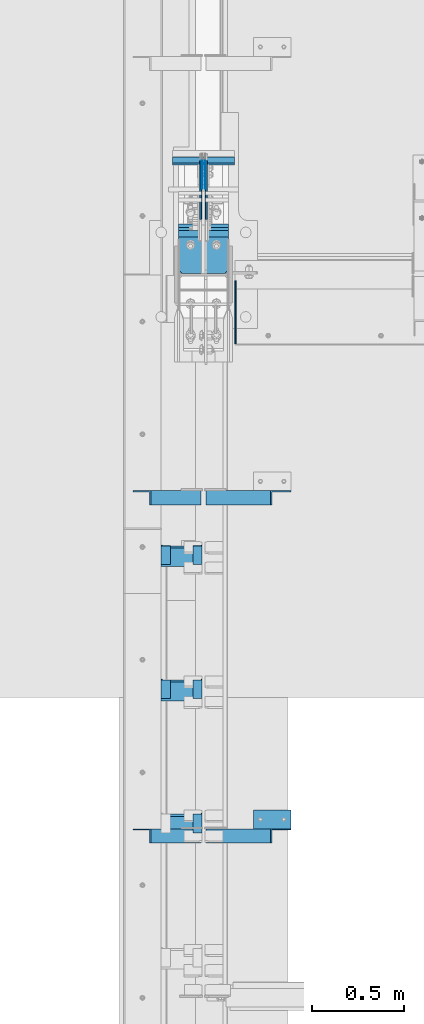
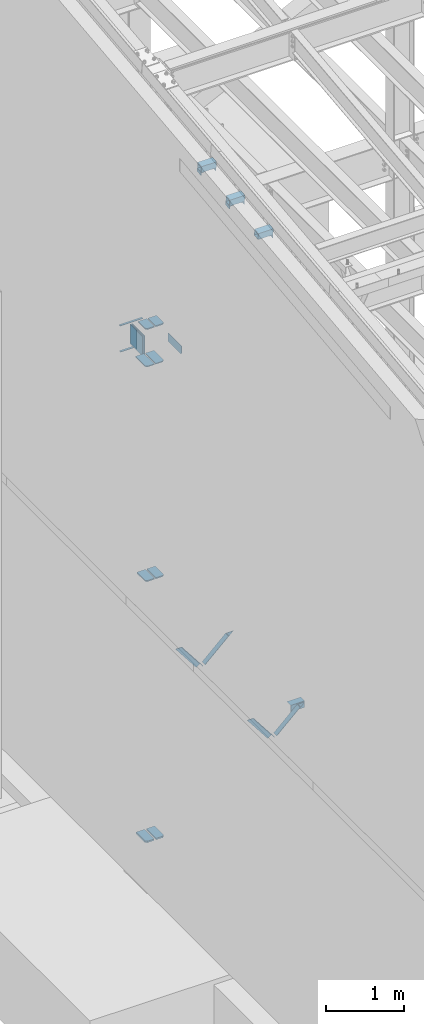
# One storey, part 829 of 1179: 24 beams, 4 members, 17 elements without a shape of their own.
"""IFC2X3 building model written with IfcOpenShell, lengths in millimetres."""

from ifc_helpers import new_model, si_unit, frame, origin_with_axes, place, context, subcontext, project, spatial, faceted_brep, material, type_object, element, aggregate, save


model = new_model("IFC2X3")

# Units and contexts
model_context = context("Model", 3, precision=1e-05, world=origin_with_axes())
body_context = subcontext(model_context, "Body", "Model", "MODEL_VIEW")
ifc_project = project(units=[si_unit("LENGTHUNIT", "METRE", prefix="MILLI"), si_unit("AREAUNIT", "SQUARE_METRE"), si_unit("VOLUMEUNIT", "CUBIC_METRE"), si_unit("MASSUNIT", "GRAM", prefix="KILO"), si_unit("TIMEUNIT", "SECOND"), si_unit("PLANEANGLEUNIT", "RADIAN"), si_unit("SOLIDANGLEUNIT", "STERADIAN"), si_unit("THERMODYNAMICTEMPERATUREUNIT", "DEGREE_CELSIUS"), si_unit("LUMINOUSINTENSITYUNIT", "LUMEN")], contexts=[model_context])

# Site, building, storey
site_placement = place(None, origin_with_axes())
site = spatial("IfcSite", under=ifc_project, at=site_placement, CompositionType="ELEMENT")
building_placement = place(site_placement, origin_with_axes())
building = spatial("IfcBuilding", under=site, at=building_placement, Name="Undefined", CompositionType="ELEMENT")
storey_placement = place(building_placement, origin_with_axes())
storey = spatial("IfcBuildingStorey", under=building, at=storey_placement, Name="Undefined", CompositionType="ELEMENT", Elevation=0.0)

# Assembly, member
assembly_1_placement = place(storey_placement, origin_with_axes())
assembly_1 = element("IfcElementAssembly", 1, at=assembly_1_placement, inside=storey, Name="ANGLE", AssemblyPlace="NOTDEFINED", PredefinedType="RIGID_FRAME")
ifc_material_1 = material(Name="STEEL/A36")
member_type = type_object("IfcMemberType", Name="L3X3X1/4", PredefinedType="NOTDEFINED")
member_1_placement = place(assembly_1_placement, frame((472.414639168561, 25844.5, 3736.19330123132), z_axis=(0.0, -1.0, 0.0), x_axis=(0.729484494811633, 0.0, 0.683997347823379)))
member_1 = element("IfcMember", 2, at=member_1_placement, type_object=member_type, material=ifc_material_1, Name="ANGLE", ObjectType="L3X3X1/4", context=body_context, shape_type="Brep", body=[
    faceted_brep([(0.0, 38.0999999999985, -38.0999999999999), (0.0, 38.0999999999985, 38.0999999999999), (475.752341075195, 38.0999999999181, 38.1000000000004), (475.752341075195, 38.0999999999181, -38.1000000000004), (0.0, 31.75, 38.1000000000004), (482.524628360803, 31.7499999999177, 38.1000000000004), (0.0, 31.75, -31.75), (482.524628360803, 31.7499999999177, -31.75), (0.0, -38.0999999999985, -31.75), (557.019788502486, -38.1000000000854, -31.75), (0.0, -38.0999999999985, -38.0999999999999), (557.019788502486, -38.1000000000854, -38.1000000000004)], [[[0, 1, 2, 3]], [[1, 4, 5, 2]], [[4, 6, 7, 5]], [[6, 8, 9, 7]], [[8, 10, 11, 9]], [[10, 0, 3, 11]], [[5, 7, 9, 11, 3, 2]], [[10, 8, 6, 4, 1, 0]]]),
])
aggregate(assembly_1, [member_1])

assembly_2_placement = place(storey_placement, origin_with_axes())
assembly_2 = element("IfcElementAssembly", 3, at=assembly_2_placement, inside=storey, Name="ANGLE", AssemblyPlace="NOTDEFINED", PredefinedType="RIGID_FRAME")
member_2_placement = place(assembly_2_placement, frame((472.414639168561, 24015.7, 3736.19330123132), z_axis=(0.0, -1.0, 0.0), x_axis=(0.729484494811633, 0.0, 0.683997347823379)))
member_2 = element("IfcMember", 4, at=member_2_placement, type_object=member_type, material=ifc_material_1, Name="ANGLE", ObjectType="L3X3X1/4", context=body_context, shape_type="Brep", body=[
    faceted_brep([(0.0, 38.0999999999985, -38.0999999999999), (0.0, 38.0999999999985, 38.0999999999999), (475.752341075195, 38.0999999999181, 38.1000000000004), (475.752341075195, 38.0999999999181, -38.1000000000004), (0.0, 31.75, 38.1000000000004), (482.524628360803, 31.7499999999177, 38.1000000000004), (0.0, 31.75, -31.75), (482.524628360803, 31.7499999999177, -31.75), (0.0, -38.0999999999985, -31.75), (557.019788502486, -38.1000000000854, -31.75), (0.0, -38.0999999999985, -38.0999999999999), (557.019788502486, -38.1000000000854, -38.1000000000004)], [[[0, 1, 2, 3]], [[1, 4, 5, 2]], [[4, 6, 7, 5]], [[6, 8, 9, 7]], [[8, 10, 11, 9]], [[10, 0, 3, 11]], [[5, 7, 9, 11, 3, 2]], [[10, 8, 6, 4, 1, 0]]]),
])
aggregate(assembly_2, [member_2])

assembly_3_placement = place(storey_placement, origin_with_axes())
assembly_3 = element("IfcElementAssembly", 5, at=assembly_3_placement, inside=storey, Name="ANGLE", AssemblyPlace="NOTDEFINED", PredefinedType="RIGID_FRAME")
member_3_placement = place(assembly_3_placement, frame((80.8196258456446, 25844.5, 4125.56128839178), z_axis=(0.0, -1.0, 0.0), x_axis=(0.614083067285056, 0.0, -0.789241399366364)))
member_3 = element("IfcMember", 6, at=member_3_placement, type_object=member_type, material=ifc_material_1, Name="ANGLE", ObjectType="L3X3X1/4", context=body_context, shape_type="Brep", body=[
    faceted_brep([(59.3707492954454, 38.0999999999781, -38.1000000000004), (59.3707492954454, 38.0999999999781, 38.1000000000004), (499.083854779058, 38.0999999998585, 38.1000000000004), (499.083854779058, 38.0999999998585, -38.1000000000004), (54.4300207928691, 31.7499999999804, 38.1000000000004), (499.083854779056, 31.7499999998595, 38.1000000000004), (54.4300207928691, 31.7499999999804, -31.75), (499.083854779056, 31.7499999998595, -31.75), (0.0820072645328764, -38.0999999999945, -31.75), (499.083854779043, -38.10000000013, -31.75), (0.0820072645328764, -38.0999999999945, -38.1000000000004), (499.083854779043, -38.10000000013, -38.1000000000004)], [[[0, 1, 2, 3]], [[1, 4, 5, 2]], [[4, 6, 7, 5]], [[6, 8, 9, 7]], [[8, 10, 11, 9]], [[10, 0, 3, 11]], [[5, 7, 9, 11, 3, 2]], [[10, 8, 6, 4, 1, 0]]]),
])
aggregate(assembly_3, [member_3])

assembly_4_placement = place(storey_placement, origin_with_axes())
assembly_4 = element("IfcElementAssembly", 7, at=assembly_4_placement, inside=storey, Name="ANGLE", AssemblyPlace="NOTDEFINED", PredefinedType="RIGID_FRAME")
member_4_placement = place(assembly_4_placement, frame((80.8196258456446, 24015.7, 4125.56128839178), z_axis=(0.0, -1.0, 0.0), x_axis=(0.614083067285056, 0.0, -0.789241399366364)))
member_4 = element("IfcMember", 8, at=member_4_placement, type_object=member_type, material=ifc_material_1, Name="ANGLE", ObjectType="L3X3X1/4", context=body_context, shape_type="Brep", body=[
    faceted_brep([(59.3707492954454, 38.0999999999781, -38.1000000000004), (59.3707492954454, 38.0999999999781, 38.1000000000004), (499.083854779058, 38.0999999998585, 38.1000000000004), (499.083854779058, 38.0999999998585, -38.1000000000004), (54.4300207928691, 31.7499999999804, 38.1000000000004), (499.083854779056, 31.7499999998595, 38.1000000000004), (54.4300207928691, 31.7499999999804, -31.75), (499.083854779056, 31.7499999998595, -31.75), (0.0820072645328764, -38.0999999999945, -31.75), (499.083854779043, -38.10000000013, -31.75), (0.0820072645328764, -38.0999999999945, -38.1000000000004), (499.083854779043, -38.10000000013, -38.1000000000004)], [[[0, 1, 2, 3]], [[1, 4, 5, 2]], [[4, 6, 7, 5]], [[6, 8, 9, 7]], [[8, 10, 11, 9]], [[10, 0, 3, 11]], [[5, 7, 9, 11, 3, 2]], [[10, 8, 6, 4, 1, 0]]]),
])
aggregate(assembly_4, [member_4])

# Assembly, beams
assembly_5_placement = place(storey_placement, origin_with_axes())
assembly_5 = element("IfcElementAssembly", 9, at=assembly_5_placement, inside=storey, Name="BEAM", AssemblyPlace="NOTDEFINED", PredefinedType="RIGID_FRAME")
ifc_material_2 = material(Name="STEEL/A572-GR.50")
beam_type_1 = type_object("IfcBeamType", PredefinedType="NOTDEFINED")
beam_1_placement = place(assembly_5_placement, frame((431.80003662088, 27643.7268058729, 7589.8375), z_axis=(-1.0, 0.0, 0.0), x_axis=(0.0, 1.0, 0.0)))
beam_1 = element("IfcBeam", 10, at=beam_1_placement, type_object=beam_type_1, material=ifc_material_2, Name="PLATE", context=body_context, shape_type="Brep", body=[
    faceted_brep([(0.0, 4.76249999999982, -168.275000000001), (0.0, 4.76250000000073, 168.275), (31.75, 4.76249999999982, 168.275000000001), (31.75, 4.76249999999982, -168.275000000001), (0.0, -4.76250000000073, 168.275), (31.75, -4.76249999999982, 168.275000000001), (0.0, -4.76249999999982, -168.275000000001), (31.75, -4.76249999999982, -168.275000000001)], [[[0, 1, 2, 3]], [[1, 4, 5, 2]], [[4, 6, 7, 5]], [[6, 0, 3, 7]], [[5, 7, 3, 2]], [[6, 4, 1, 0]]]),
])
beam_2_placement = place(assembly_5_placement, frame((431.80003662088, 27654.8389034115, 7989.4905), z_axis=(-1.0, 0.0, 0.0), x_axis=(0.0, 1.0, 0.0)))
beam_2 = element("IfcBeam", 11, at=beam_2_placement, type_object=beam_type_1, material=ifc_material_2, Name="PLATE", context=body_context, shape_type="Brep", body=[
    faceted_brep([(0.0, 4.76249999999982, -168.275000000001), (0.0, 4.76250000000073, 168.275), (31.75, 4.76249999999982, 168.275000000001), (31.75, 4.76249999999982, -168.275000000001), (0.0, -4.76250000000073, 168.275), (31.75, -4.76249999999982, 168.275000000001), (0.0, -4.76249999999982, -168.275000000001), (31.75, -4.76249999999982, -168.275000000001)], [[[0, 1, 2, 3]], [[1, 4, 5, 2]], [[4, 6, 7, 5]], [[6, 0, 3, 7]], [[5, 7, 3, 2]], [[6, 4, 1, 0]]]),
])

assembly_6_placement = place(storey_placement, origin_with_axes())
assembly_6 = element("IfcElementAssembly", 12, at=assembly_6_placement, inside=storey, Name="COLUMN", AssemblyPlace="NOTDEFINED", PredefinedType="RIGID_FRAME")
beam_type_2 = type_object("IfcBeamType", PredefinedType="NOTDEFINED")
beam_3_placement = place(assembly_6_placement, frame((505.619000000002, 27288.7322991348, 4353.49928057188), z_axis=(1.0, 0.0, 0.0), x_axis=(0.0, -1.0, 0.0)))
beam_3 = element("IfcBeam", 13, at=beam_3_placement, type_object=beam_type_2, material=ifc_material_2, Name="PLATE", context=body_context, shape_type="Brep", body=[
    faceted_brep([(231.382299134722, -9.52499999999964, 42.8617503813238), (231.382299134766, 9.52499999999964, 42.8617503813238), (211.537549516099, 9.52499999999964, 62.7065), (211.537549516099, -9.52499999999964, 62.7065), (6.18456397205591e-11, -9.52499999999964, -62.7065000000084), (0.0, -9.52499999999964, 62.7065000000002), (0.0, 9.52499999999964, 62.7065000000002), (6.18456397205591e-11, 9.52499999999964, -62.7065000000084), (231.382299199602, 9.52499999999964, -62.7065000000002), (231.382299199602, -9.52499999999964, -62.7065000000002)], [[[0, 1, 2, 3]], [[4, 5, 6, 7]], [[4, 7, 8, 9]], [[5, 4, 9, 0, 3]], [[6, 5, 3, 2]], [[8, 7, 6, 2, 1]], [[9, 8, 1, 0]]]),
])
beam_4_placement = place(assembly_6_placement, frame((357.981000000002, 27288.7322991348, 4353.49928057188), z_axis=(-1.0, 0.0, 0.0), x_axis=(0.0, -1.0, 0.0)))
beam_4 = element("IfcBeam", 14, at=beam_4_placement, type_object=beam_type_2, material=ifc_material_2, Name="PLATE", context=body_context, shape_type="Brep", body=[
    faceted_brep([(231.38229913473, -9.52499999999964, 42.8620431057086), (231.382299134766, 9.52499999999964, 42.8620431057086), (211.537842240497, 9.52499999999964, 62.7065), (211.537842240497, -9.52499999999964, 62.7065), (6.18456397205591e-11, -9.52499999999964, -62.7065000000084), (0.0, -9.52499999999964, 62.7065000000002), (0.0, 9.52499999999964, 62.7065000000002), (6.18456397205591e-11, 9.52499999999964, -62.7065000000084), (231.382299199602, 9.52499999999964, -62.7065000000002), (231.382299199602, -9.52499999999964, -62.7065000000002)], [[[0, 1, 2, 3]], [[4, 5, 6, 7]], [[4, 7, 8, 9]], [[5, 4, 9, 0, 3]], [[6, 5, 3, 2]], [[8, 7, 6, 2, 1]], [[9, 8, 1, 0]]]),
])

# Assembly, beam
assembly_7_placement = place(storey_placement, origin_with_axes())
assembly_7 = element("IfcElementAssembly", 15, at=assembly_7_placement, inside=storey, Name="BEAM", AssemblyPlace="NOTDEFINED", PredefinedType="RIGID_FRAME")
beam_type_3 = type_object("IfcBeamType", Name="L2X2X1/4", PredefinedType="NOTDEFINED")
beam_5_placement = place(assembly_7_placement, frame((228.599999999967, 25587.0004508329, 11703.4894001851), z_axis=(0.0, 0.112284087038014, -0.993676146336441), x_axis=(0.0, -0.993676146336441, -0.112284087038017)))
beam_5 = element("IfcBeam", 16, at=beam_5_placement, type_object=beam_type_3, material=ifc_material_1, Name="ANGLE", ObjectType="L2X2X1/4", context=body_context, shape_type="Brep", body=[
    faceted_brep([(0.0, 25.3999999999996, -25.4000000000015), (0.0, 25.3999999999996, 25.4000000000015), (101.599999999555, 25.4, 25.3999999999451), (101.599999999537, 25.4, -25.4000000000251), (7.27595761418343e-12, 19.05, 25.3999999999851), (101.599999999555, 19.05, 25.3999999999451), (0.0, 19.0499992350015, -19.0499992349996), (101.600003324515, 19.0499992350051, -19.0499992350015), (-1.09139364212751e-11, -25.4, -19.0499999999865), (101.59999999954, -25.4, -19.0500000000302), (0.0, -25.3999999999996, -25.4000000000015), (101.599999999537, -25.4, -25.4000000000251)], [[[0, 1, 2, 3]], [[1, 4, 5, 2]], [[4, 6, 7, 5]], [[6, 8, 9, 7]], [[8, 10, 11, 9]], [[10, 0, 3, 11]], [[5, 7, 9, 11, 3, 2]], [[10, 8, 6, 4, 1, 0]]]),
])

assembly_8_placement = place(storey_placement, origin_with_axes())
assembly_8 = element("IfcElementAssembly", 17, at=assembly_8_placement, inside=storey, Name="BEAM", AssemblyPlace="NOTDEFINED", PredefinedType="RIGID_FRAME")
beam_6_placement = place(assembly_8_placement, frame((399.256249999966, 25587.0004508329, 11703.4894001851), z_axis=(-1.0, 0.0, 0.0), x_axis=(0.0, -0.993676146336441, -0.112284087038017)))
beam_6 = element("IfcBeam", 18, at=beam_6_placement, type_object=beam_type_3, material=ifc_material_1, Name="ANGLE", ObjectType="L2X2X1/4", context=body_context, shape_type="Brep", body=[
    faceted_brep([(0.0, 25.3999999999996, -25.4000000000015), (0.0, 25.3999999999996, 25.4000000000015), (101.599999999555, 25.4, 25.3999999999451), (101.599999999537, 25.4, -25.4000000000251), (7.27595761418343e-12, 19.05, 25.3999999999851), (101.599999999555, 19.05, 25.3999999999451), (0.0, 19.0499992350015, -19.0499992349996), (101.600003324515, 19.0499992350051, -19.0499992350015), (-1.09139364212751e-11, -25.4, -19.0499999999865), (101.59999999954, -25.4, -19.0500000000302), (0.0, -25.3999999999996, -25.4000000000015), (101.599999999537, -25.4, -25.4000000000251)], [[[0, 1, 2, 3]], [[1, 4, 5, 2]], [[4, 6, 7, 5]], [[6, 8, 9, 7]], [[8, 10, 11, 9]], [[10, 0, 3, 11]], [[5, 7, 9, 11, 3, 2]], [[10, 8, 6, 4, 1, 0]]]),
])

# Beam
beam_7_placement = place(assembly_7_placement, frame((228.599999999967, 24861.0935889291, 11621.4642426498), z_axis=(0.0, 0.112284087038014, -0.993676146336441), x_axis=(0.0, -0.993676146336441, -0.112284087038017)))
beam_7 = element("IfcBeam", 19, at=beam_7_placement, type_object=beam_type_3, material=ifc_material_1, Name="ANGLE", ObjectType="L2X2X1/4", context=body_context, shape_type="Brep", body=[
    faceted_brep([(0.0, 25.3999999999996, -25.4000000000015), (0.0, 25.3999999999996, 25.4000000000015), (101.599999999555, 25.4, 25.3999999999451), (101.599999999537, 25.4, -25.4000000000251), (7.27595761418343e-12, 19.05, 25.3999999999851), (101.599999999555, 19.05, 25.3999999999451), (0.0, 19.0499992350015, -19.0499992349996), (101.600003324515, 19.0499992350051, -19.0499992350015), (-1.09139364212751e-11, -25.4, -19.0499999999865), (101.59999999954, -25.4, -19.0500000000302), (0.0, -25.3999999999996, -25.4000000000015), (101.599999999537, -25.4, -25.4000000000251)], [[[0, 1, 2, 3]], [[1, 4, 5, 2]], [[4, 6, 7, 5]], [[6, 8, 9, 7]], [[8, 10, 11, 9]], [[10, 0, 3, 11]], [[5, 7, 9, 11, 3, 2]], [[10, 8, 6, 4, 1, 0]]]),
])

aggregate(assembly_7, [beam_5, beam_7])

beam_8_placement = place(assembly_8_placement, frame((399.256249999966, 24861.0935889291, 11621.4642426498), z_axis=(-1.0, 0.0, 0.0), x_axis=(0.0, -0.993676146336441, -0.112284087038017)))
beam_8 = element("IfcBeam", 20, at=beam_8_placement, type_object=beam_type_3, material=ifc_material_1, Name="ANGLE", ObjectType="L2X2X1/4", context=body_context, shape_type="Brep", body=[
    faceted_brep([(0.0, 25.3999999999996, -25.4000000000015), (0.0, 25.3999999999996, 25.4000000000015), (101.599999999555, 25.4, 25.3999999999451), (101.599999999537, 25.4, -25.4000000000251), (7.27595761418343e-12, 19.05, 25.3999999999851), (101.599999999555, 19.05, 25.3999999999451), (0.0, 19.0499992350015, -19.0499992349996), (101.600003324515, 19.0499992350051, -19.0499992350015), (-1.09139364212751e-11, -25.4, -19.0499999999865), (101.59999999954, -25.4, -19.0500000000302), (0.0, -25.3999999999996, -25.4000000000015), (101.599999999537, -25.4, -25.4000000000251)], [[[0, 1, 2, 3]], [[1, 4, 5, 2]], [[4, 6, 7, 5]], [[6, 8, 9, 7]], [[8, 10, 11, 9]], [[10, 0, 3, 11]], [[5, 7, 9, 11, 3, 2]], [[10, 8, 6, 4, 1, 0]]]),
])

beam_9_placement = place(assembly_8_placement, frame((399.256249999966, 24135.1959181465, 11539.3576516566), z_axis=(-1.0, 0.0, 0.0), x_axis=(0.0, -0.993676146336441, -0.112284087038017)))
beam_9 = element("IfcBeam", 21, at=beam_9_placement, type_object=beam_type_3, material=ifc_material_1, Name="ANGLE", ObjectType="L2X2X1/4", context=body_context, shape_type="Brep", body=[
    faceted_brep([(0.0, 25.3999999999996, -25.4000000000015), (0.0, 25.3999999999996, 25.4000000000015), (101.599999999555, 25.4, 25.3999999999451), (101.599999999537, 25.4, -25.4000000000251), (7.27595761418343e-12, 19.05, 25.3999999999851), (101.599999999555, 19.05, 25.3999999999451), (0.0, 19.0499992350015, -19.0499992349996), (101.600003324515, 19.0499992350051, -19.0499992350015), (-1.09139364212751e-11, -25.4, -19.0499999999865), (101.59999999954, -25.4, -19.0500000000302), (0.0, -25.3999999999996, -25.4000000000015), (101.599999999537, -25.4, -25.4000000000251)], [[[0, 1, 2, 3]], [[1, 4, 5, 2]], [[4, 6, 7, 5]], [[6, 8, 9, 7]], [[8, 10, 11, 9]], [[10, 0, 3, 11]], [[5, 7, 9, 11, 3, 2]], [[10, 8, 6, 4, 1, 0]]]),
])

aggregate(assembly_8, [beam_6, beam_8, beam_9])

beam_type_4 = type_object("IfcBeamType", PredefinedType="NOTDEFINED")
beam_10_placement = place(assembly_6_placement, frame((358.775000000002, 27057.35, 8284.053435263), z_axis=(-1.0, 0.0, 0.0), x_axis=(0.0, 1.0, 0.0)))
beam_10 = element("IfcBeam", 22, at=beam_10_placement, type_object=beam_type_4, material=ifc_material_2, Name="PLATE", context=body_context, shape_type="Brep", body=[
    faceted_brep([(1.81898940354586e-11, -9.52499999999782, 41.2750000000015), (22.2250000000204, -9.525000000006, 63.5), (22.2249999999913, 9.52499999999327, 63.5), (-7.27595761418343e-12, 9.52500000000146, 41.2750000000015), (198.4375, 9.52499999999964, 63.5), (198.4375, 9.52499999999964, -63.5), (0.0, 9.52500000000146, -63.5), (198.4375, -9.52499999999964, 63.5), (0.0, -9.52500000000146, -63.5), (198.4375, -9.52499999999964, -63.5)], [[[0, 1, 2, 3]], [[4, 5, 6, 3, 2]], [[7, 4, 2, 1]], [[8, 9, 7, 1, 0]], [[8, 6, 5, 9]], [[7, 9, 5, 4]], [[6, 8, 0, 3]]]),
])

beam_11_placement = place(assembly_6_placement, frame((504.825000000001, 27057.35, 8284.053435263), z_axis=(-1.0, 0.0, 0.0), x_axis=(0.0, 1.0, 0.0)))
beam_11 = element("IfcBeam", 23, at=beam_11_placement, type_object=beam_type_4, material=ifc_material_2, Name="PLATE", context=body_context, shape_type="Brep", body=[
    faceted_brep([(22.2250000000204, -9.525000000006, -63.5), (1.81898940354586e-11, -9.52499999999782, -41.2750000000015), (-7.27595761418343e-12, 9.52500000000146, -41.2750000000015), (22.2249999999913, 9.52499999999327, -63.5), (0.0, 9.52500000000146, 63.5), (198.4375, 9.52499999999964, 63.5), (198.4375, 9.52499999999964, -63.5), (0.0, -9.52500000000146, 63.5), (198.4375, -9.52499999999964, 63.5), (198.4375, -9.52499999999964, -63.5)], [[[0, 1, 2, 3]], [[4, 5, 6, 3, 2]], [[4, 7, 8, 5]], [[9, 8, 7, 1, 0]], [[6, 9, 0, 3]], [[8, 9, 6, 5]], [[7, 4, 2, 1]]]),
])

beam_type_5 = type_object("IfcBeamType", PredefinedType="NOTDEFINED")
beam_12_placement = place(assembly_6_placement, frame((358.775000000002, 27057.35, 7699.37500000912), z_axis=(-1.0, 0.0, 0.0), x_axis=(0.0, 1.0, 0.0)))
beam_12 = element("IfcBeam", 24, at=beam_12_placement, type_object=beam_type_5, material=ifc_material_2, Name="PLATE", context=body_context, shape_type="Brep", body=[
    faceted_brep([(22.2249999999985, 6.35000000000036, 63.5), (0.0, 6.35000000000036, 41.275), (0.0, -6.35000000000036, 41.275), (22.2249999999985, -6.35000000000036, 63.5), (267.288903411474, 6.35000000000036, 63.5), (267.288903411474, 6.35000000000036, -63.5), (0.0, 6.35000000000036, -63.5), (267.288903411474, -6.35000000000036, 63.5), (0.0, -6.35000000000036, -63.5), (267.288903411474, -6.35000000000036, -63.5)], [[[0, 1, 2, 3]], [[4, 5, 6, 1, 0]], [[7, 4, 0, 3]], [[8, 9, 7, 3, 2]], [[8, 6, 5, 9]], [[7, 9, 5, 4]], [[6, 8, 2, 1]]]),
])

beam_13_placement = place(assembly_6_placement, frame((504.825000000001, 27057.35, 7699.37500000912), z_axis=(-1.0, 0.0, 0.0), x_axis=(0.0, 1.0, 0.0)))
beam_13 = element("IfcBeam", 25, at=beam_13_placement, type_object=beam_type_5, material=ifc_material_2, Name="PLATE", context=body_context, shape_type="Brep", body=[
    faceted_brep([(22.2249999999985, -6.35000000000036, -63.5), (0.0, -6.35000000000036, -41.275), (0.0, 6.35000000000036, -41.275), (22.2249999999985, 6.35000000000036, -63.5), (0.0, 6.35000000000036, 63.5), (267.288903411474, 6.35000000000036, 63.5), (267.288903411474, 6.35000000000036, -63.5), (0.0, -6.35000000000036, 63.5), (267.288903411474, -6.35000000000036, 63.5), (267.288903411474, -6.35000000000036, -63.5)], [[[0, 1, 2, 3]], [[4, 5, 6, 3, 2]], [[4, 7, 8, 5]], [[9, 8, 7, 1, 0]], [[6, 9, 0, 3]], [[8, 9, 6, 5]], [[7, 4, 2, 1]]]),
])

aggregate(assembly_6, [beam_12, beam_13, beam_10, beam_11, beam_3, beam_4])

# Assembly, beam
assembly_9_placement = place(storey_placement, origin_with_axes())
assembly_9 = element("IfcElementAssembly", 26, at=assembly_9_placement, inside=storey, Name="ANGLE", AssemblyPlace="NOTDEFINED", PredefinedType="RIGID_FRAME")
beam_type_6 = type_object("IfcBeamType", Name="L4X4X1/4", PredefinedType="NOTDEFINED")
beam_14_placement = place(assembly_9_placement, frame((701.59635534156, 24104.6, 4051.3), z_axis=(0.0, 0.0, -1.0), x_axis=(1.0, 0.0, 0.0)))
beam_14 = element("IfcBeam", 27, at=beam_14_placement, type_object=beam_type_6, material=ifc_material_1, Name="ANGLE", ObjectType="L4X4X1/4", context=body_context, shape_type="Brep", body=[
    faceted_brep([(1.90993887372315e-11, 50.8000000000002, -50.8000000000002), (1.90993887372315e-11, 50.8000000000002, 50.8000000000002), (203.200000000001, 50.7999999999993, 50.8000000000002), (203.200000000001, 50.7999999999993, -50.8000000000002), (0.0, 44.4500000000007, 50.8000000000002), (203.200000000001, 44.4500000000007, 50.8000000000002), (0.0, 44.4500000000007, -44.4499999999998), (203.200000000001, 44.4500000000007, -44.4499999999998), (0.0, -50.7999999999993, -44.4499999999998), (203.200000000001, -50.7999999999993, -44.4499999999998), (-1.81898940354586e-11, -50.7999999999997, -50.8000000000002), (203.200000000001, -50.7999999999993, -50.8000000000002)], [[[0, 1, 2, 3]], [[1, 4, 5, 2]], [[4, 6, 7, 5]], [[6, 8, 9, 7]], [[8, 10, 11, 9]], [[10, 0, 3, 11]], [[5, 7, 9, 11, 3, 2]], [[10, 8, 6, 4, 1, 0]]]),
])
aggregate(assembly_9, [beam_14])

assembly_10_placement = place(storey_placement, origin_with_axes())
assembly_10 = element("IfcElementAssembly", 28, at=assembly_10_placement, inside=storey, Name="BEAM", AssemblyPlace="NOTDEFINED", PredefinedType="RIGID_FRAME")
beam_type_7 = type_object("IfcBeamType", PredefinedType="NOTDEFINED")
beam_15_placement = place(assembly_10_placement, frame((604.837461237323, 26676.35, 8083.55000610352), z_axis=(0.0, 0.0, 1.0), x_axis=(0.0, 1.0, 0.0)))
beam_15 = element("IfcBeam", 29, at=beam_15_placement, type_object=beam_type_7, material=ifc_material_1, Name="PLATE", context=body_context, shape_type="Brep", body=[
    faceted_brep([(0.0, 3.17499999999995, -44.4499999999998), (19.0499999999993, 3.17499999999995, -63.5), (19.0499999999993, -3.17499999999995, -63.5), (0.0, -3.17499999999995, -44.4499999999998), (0.0, 3.17499999999927, 63.5), (342.899999237059, 3.17499999999995, 63.5), (342.899999237059, 3.17499999999995, -63.5), (0.0, -3.17499999999927, 63.5), (342.899999237059, -3.17499999999995, 63.5), (342.899999237059, -3.17499999999995, -63.5)], [[[0, 1, 2, 3]], [[4, 5, 6, 1, 0]], [[4, 7, 8, 5]], [[9, 8, 7, 3, 2]], [[6, 9, 2, 1]], [[8, 9, 6, 5]], [[7, 4, 0, 3]]]),
])
aggregate(assembly_10, [beam_15])

# Beam
beam_type_8 = type_object("IfcBeamType", PredefinedType="NOTDEFINED")
beam_16_placement = place(assembly_5_placement, frame((424.656250000001, 27667.5389034115, 7804.15), z_axis=(0.0, 0.0, -1.0), x_axis=(0.0, -1.0, 0.0)))
beam_16 = element("IfcBeam", 30, at=beam_16_placement, type_object=beam_type_8, material=ifc_material_2, Name="PLATE", context=body_context, shape_type="Brep", body=[
    faceted_brep([(0.0, 1.58750000000146, -152.4), (0.0, 1.58750000000146, 152.4), (152.400000000009, 1.58750000000146, 152.4), (152.400000000009, 1.58750000000146, -152.4), (0.0, -1.58750000000146, 152.4), (152.400000000009, -1.58750000000146, 152.4), (0.0, -1.58750000000146, -152.4), (152.400000000009, -1.58750000000146, -152.4)], [[[0, 1, 2, 3]], [[1, 4, 5, 2]], [[4, 6, 7, 5]], [[6, 0, 3, 7]], [[5, 7, 3, 2]], [[6, 4, 1, 0]]]),
])

beam_17_placement = place(assembly_5_placement, frame((438.943750000001, 27667.5389034115, 7804.15), z_axis=(0.0, 0.0, -1.0), x_axis=(0.0, -1.0, 0.0)))
beam_17 = element("IfcBeam", 31, at=beam_17_placement, type_object=beam_type_8, material=ifc_material_2, Name="PLATE", context=body_context, shape_type="Brep", body=[
    faceted_brep([(0.0, 1.58750000000146, -152.4), (0.0, 1.58750000000146, 152.4), (152.400000000009, 1.58750000000146, 152.4), (152.400000000009, 1.58750000000146, -152.4), (0.0, -1.58750000000146, 152.4), (152.400000000009, -1.58750000000146, 152.4), (0.0, -1.58750000000146, -152.4), (152.400000000009, -1.58750000000146, -152.4)], [[[0, 1, 2, 3]], [[1, 4, 5, 2]], [[4, 6, 7, 5]], [[6, 0, 3, 7]], [[5, 7, 3, 2]], [[6, 4, 1, 0]]]),
])

aggregate(assembly_5, [beam_1, beam_2, beam_16, beam_17])

# Assembly, beam
assembly_11_placement = place(storey_placement, origin_with_axes())
assembly_11 = element("IfcElementAssembly", 32, at=assembly_11_placement, inside=storey, Name="PLATE", AssemblyPlace="NOTDEFINED", PredefinedType="RIGID_FRAME")
beam_type_9 = type_object("IfcBeamType", PredefinedType="NOTDEFINED")
beam_18_placement = place(assembly_11_placement, frame((356.3935, 27305.969501231, 285.099398203347), z_axis=(-1.0, 0.0, 0.0), x_axis=(0.0, -1.0, 0.0)))
beam_18 = element("IfcBeam", 33, at=beam_18_placement, type_object=beam_type_9, material=ifc_material_2, Name="PLATE", context=body_context, shape_type="Brep", body=[
    faceted_brep([(248.619501230954, 12.7, 38.894), (226.394501230956, 12.7, 61.119), (226.394501230956, -12.7, 61.119), (248.619501230954, -12.7, 38.894), (248.619501230954, 12.7, -61.119), (0.0, 12.7, -61.1189999999988), (0.0, 12.7, 61.1189999999988), (0.0, -12.7, 61.1189999999988), (0.0, -12.7, -61.1189999999988), (248.619501230954, -12.7, -61.119)], [[[0, 1, 2, 3]], [[4, 5, 6, 1, 0]], [[6, 7, 2, 1]], [[7, 8, 9, 3, 2]], [[8, 5, 4, 9]], [[9, 4, 0, 3]], [[8, 7, 6, 5]]]),
])
aggregate(assembly_11, [beam_18])

assembly_12_placement = place(storey_placement, origin_with_axes())
assembly_12 = element("IfcElementAssembly", 34, at=assembly_12_placement, inside=storey, Name="PLATE", AssemblyPlace="NOTDEFINED", PredefinedType="RIGID_FRAME")
beam_19_placement = place(assembly_12_placement, frame((507.2065, 27305.969501231, 285.099398203347), z_axis=(1.0, 0.0, 0.0), x_axis=(0.0, -1.0, 0.0)))
beam_19 = element("IfcBeam", 35, at=beam_19_placement, type_object=beam_type_9, material=ifc_material_2, Name="PLATE", context=body_context, shape_type="Brep", body=[
    faceted_brep([(248.619501230954, 12.7, 38.894), (226.394501230956, 12.7, 61.119), (226.394501230956, -12.7, 61.119), (248.619501230954, -12.7, 38.894), (248.619501230954, 12.7, -61.119), (0.0, 12.7, -61.1189999999988), (0.0, 12.7, 61.1189999999988), (0.0, -12.7, 61.1189999999988), (0.0, -12.7, -61.1189999999988), (248.619501230954, -12.7, -61.119)], [[[0, 1, 2, 3]], [[4, 5, 6, 1, 0]], [[6, 7, 2, 1]], [[7, 8, 9, 3, 2]], [[8, 5, 4, 9]], [[9, 4, 0, 3]], [[8, 7, 6, 5]]]),
])
aggregate(assembly_12, [beam_19])

assembly_13_placement = place(storey_placement, origin_with_axes())
assembly_13 = element("IfcElementAssembly", 36, at=assembly_13_placement, inside=storey, Name="PLATE", AssemblyPlace="NOTDEFINED", PredefinedType="RIGID_FRAME")
beam_type_10 = type_object("IfcBeamType", PredefinedType="NOTDEFINED")
beam_20_placement = place(assembly_13_placement, frame((417.512786388181, 27667.5389034115, 7804.15), z_axis=(0.0, 0.0, -1.0), x_axis=(0.0, -1.0, 0.0)))
beam_20 = element("IfcBeam", 37, at=beam_20_placement, type_object=beam_type_10, material=ifc_material_2, Name="PLATE", context=body_context, shape_type="Brep", body=[
    faceted_brep([(0.0, 4.76250000000073, -152.4), (0.0, 4.76250000000073, 152.4), (317.5, 4.76250000000073, 152.4), (317.5, 4.76250000000073, -152.4), (0.0, -4.76250000000073, 152.4), (317.5, -4.76250000000073, 152.4), (0.0, -4.76250000000073, -152.4), (317.5, -4.76250000000073, -152.4)], [[[0, 1, 2, 3]], [[1, 4, 5, 2]], [[4, 6, 7, 5]], [[6, 0, 3, 7]], [[5, 7, 3, 2]], [[6, 4, 1, 0]]]),
])
aggregate(assembly_13, [beam_20])

assembly_14_placement = place(storey_placement, origin_with_axes())
assembly_14 = element("IfcElementAssembly", 38, at=assembly_14_placement, inside=storey, Name="PLATE", AssemblyPlace="NOTDEFINED", PredefinedType="RIGID_FRAME")
beam_21_placement = place(assembly_14_placement, frame((446.087213611823, 27350.0389034115, 7804.15), z_axis=(0.0, 0.0, -1.0), x_axis=(0.0, 1.0, 0.0)))
beam_21 = element("IfcBeam", 39, at=beam_21_placement, type_object=beam_type_10, material=ifc_material_2, Name="PLATE", context=body_context, shape_type="Brep", body=[
    faceted_brep([(0.0, 4.76250000000073, -152.4), (0.0, 4.76250000000073, 152.4), (317.5, 4.76250000000073, 152.4), (317.5, 4.76250000000073, -152.4), (0.0, -4.76250000000073, 152.4), (317.5, -4.76250000000073, 152.4), (0.0, -4.76250000000073, -152.4), (317.5, -4.76250000000073, -152.4)], [[[0, 1, 2, 3]], [[1, 4, 5, 2]], [[4, 6, 7, 5]], [[6, 0, 3, 7]], [[5, 7, 3, 2]], [[6, 4, 1, 0]]]),
])
aggregate(assembly_14, [beam_21])

assembly_15_placement = place(storey_placement, origin_with_axes())
assembly_15 = element("IfcElementAssembly", 40, at=assembly_15_placement, inside=storey, Name="BEAM", AssemblyPlace="NOTDEFINED", PredefinedType="RIGID_FRAME")
ifc_material_3 = material()
beam_type_11 = type_object("IfcBeamType", Name="HSS4X4X5/16", PredefinedType="NOTDEFINED")
beam_22_placement = place(assembly_15_placement, frame((431.799999999999, 24802.0587932632, 11691.4783333789), z_axis=(0.0, -0.112284087038017, 0.993676146336441), x_axis=(-1.0, 0.0, 0.0)))
beam_22 = element("IfcBeam", 41, at=beam_22_placement, type_object=beam_type_11, material=ifc_material_3, Name="BEAM", ObjectType="HSS4X4X5/16", context=body_context, shape_type="Brep", body=[
    faceted_brep([(7.14374999999757, 42.8624999999884, -42.8624999999574), (7.14374999999757, -42.8624999999593, -42.862499999992), (228.600000000002, -42.8624999999593, -42.862499999992), (228.600000000002, 42.8624999999884, -42.8624999999574), (7.14374999999757, -42.8624999999956, 42.8624999999611), (228.600000000002, -42.8624999999956, 42.8624999999611), (7.14374999999757, 42.862499999952, 42.8624999999938), (228.600000000002, 42.862499999952, 42.8624999999938), (7.14374999999757, 50.7999999999884, -50.7999999999502), (7.14374999999757, 50.7999999999447, 50.7999999999938), (228.600000000002, 50.7999999999447, 50.7999999999938), (228.600000000002, 50.7999999999884, -50.7999999999502), (7.14374999999757, -50.7999999999956, 50.799999999952), (228.600000000002, -50.7999999999956, 50.799999999952), (7.14374999999757, -50.7999999999556, -50.7999999999902), (228.600000000002, -50.7999999999556, -50.7999999999902)], [[[0, 1, 2, 3]], [[1, 4, 5, 2]], [[4, 6, 7, 5]], [[6, 0, 3, 7]], [[8, 9, 10, 11]], [[9, 12, 13, 10]], [[12, 14, 15, 13]], [[14, 8, 11, 15]], [[13, 15, 11, 10], [5, 7, 3, 2]], [[14, 12, 9, 8], [6, 4, 1, 0]]]),
])
aggregate(assembly_15, [beam_22])

assembly_16_placement = place(storey_placement, origin_with_axes())
assembly_16 = element("IfcElementAssembly", 42, at=assembly_16_placement, inside=storey, Name="BEAM", AssemblyPlace="NOTDEFINED", PredefinedType="RIGID_FRAME")
beam_23_placement = place(assembly_16_placement, frame((431.799999999999, 24076.1611224806, 11609.3717423858), z_axis=(0.0, -0.112284087038017, 0.993676146336441), x_axis=(-1.0, 0.0, 0.0)))
beam_23 = element("IfcBeam", 43, at=beam_23_placement, type_object=beam_type_11, material=ifc_material_3, Name="BEAM", ObjectType="HSS4X4X5/16", context=body_context, shape_type="Brep", body=[
    faceted_brep([(7.14374999999757, 42.8624999999884, -42.8624999999574), (7.14374999999757, -42.8624999999593, -42.862499999992), (228.600000000002, -42.8624999999593, -42.862499999992), (228.600000000002, 42.8624999999884, -42.8624999999574), (7.14374999999757, -42.8624999999956, 42.8624999999611), (228.600000000002, -42.8624999999956, 42.8624999999611), (7.14374999999757, 42.862499999952, 42.8624999999938), (228.600000000002, 42.862499999952, 42.8624999999938), (7.14374999999757, 50.7999999999884, -50.7999999999502), (7.14374999999757, 50.7999999999447, 50.7999999999938), (228.600000000002, 50.7999999999447, 50.7999999999938), (228.600000000002, 50.7999999999884, -50.7999999999502), (7.14374999999757, -50.7999999999956, 50.799999999952), (228.600000000002, -50.7999999999956, 50.799999999952), (7.14374999999757, -50.7999999999556, -50.7999999999902), (228.600000000002, -50.7999999999556, -50.7999999999902)], [[[0, 1, 2, 3]], [[1, 4, 5, 2]], [[4, 6, 7, 5]], [[6, 0, 3, 7]], [[8, 9, 10, 11]], [[9, 12, 13, 10]], [[12, 14, 15, 13]], [[14, 8, 11, 15]], [[13, 15, 11, 10], [5, 7, 3, 2]], [[14, 12, 9, 8], [6, 4, 1, 0]]]),
])
aggregate(assembly_16, [beam_23])

assembly_17_placement = place(storey_placement, origin_with_axes())
assembly_17 = element("IfcElementAssembly", 44, at=assembly_17_placement, inside=storey, Name="BEAM", AssemblyPlace="NOTDEFINED", PredefinedType="RIGID_FRAME")
beam_24_placement = place(assembly_17_placement, frame((431.799999999999, 25527.965655167, 11773.5034909142), z_axis=(0.0, -0.112284087038017, 0.993676146336441), x_axis=(-1.0, 0.0, 0.0)))
beam_24 = element("IfcBeam", 45, at=beam_24_placement, type_object=beam_type_11, material=ifc_material_3, Name="BEAM", ObjectType="HSS4X4X5/16", context=body_context, shape_type="Brep", body=[
    faceted_brep([(7.14374999999757, 42.8624999999884, -42.8624999999574), (7.14374999999757, -42.8624999999593, -42.862499999992), (228.600000000002, -42.8624999999593, -42.862499999992), (228.600000000002, 42.8624999999884, -42.8624999999574), (7.14374999999757, -42.8624999999956, 42.8624999999611), (228.600000000002, -42.8624999999956, 42.8624999999611), (7.14374999999757, 42.862499999952, 42.8624999999938), (228.600000000002, 42.862499999952, 42.8624999999938), (7.14374999999757, 50.7999999999884, -50.7999999999502), (7.14374999999757, 50.7999999999447, 50.7999999999938), (228.600000000002, 50.7999999999447, 50.7999999999938), (228.600000000002, 50.7999999999884, -50.7999999999502), (7.14374999999757, -50.7999999999956, 50.799999999952), (228.600000000002, -50.7999999999956, 50.799999999952), (7.14374999999757, -50.7999999999556, -50.7999999999902), (228.600000000002, -50.7999999999556, -50.7999999999902)], [[[0, 1, 2, 3]], [[1, 4, 5, 2]], [[4, 6, 7, 5]], [[6, 0, 3, 7]], [[8, 9, 10, 11]], [[9, 12, 13, 10]], [[12, 14, 15, 13]], [[14, 8, 11, 15]], [[13, 15, 11, 10], [5, 7, 3, 2]], [[14, 12, 9, 8], [6, 4, 1, 0]]]),
])
aggregate(assembly_17, [beam_24])

save(model, "model.ifc")
